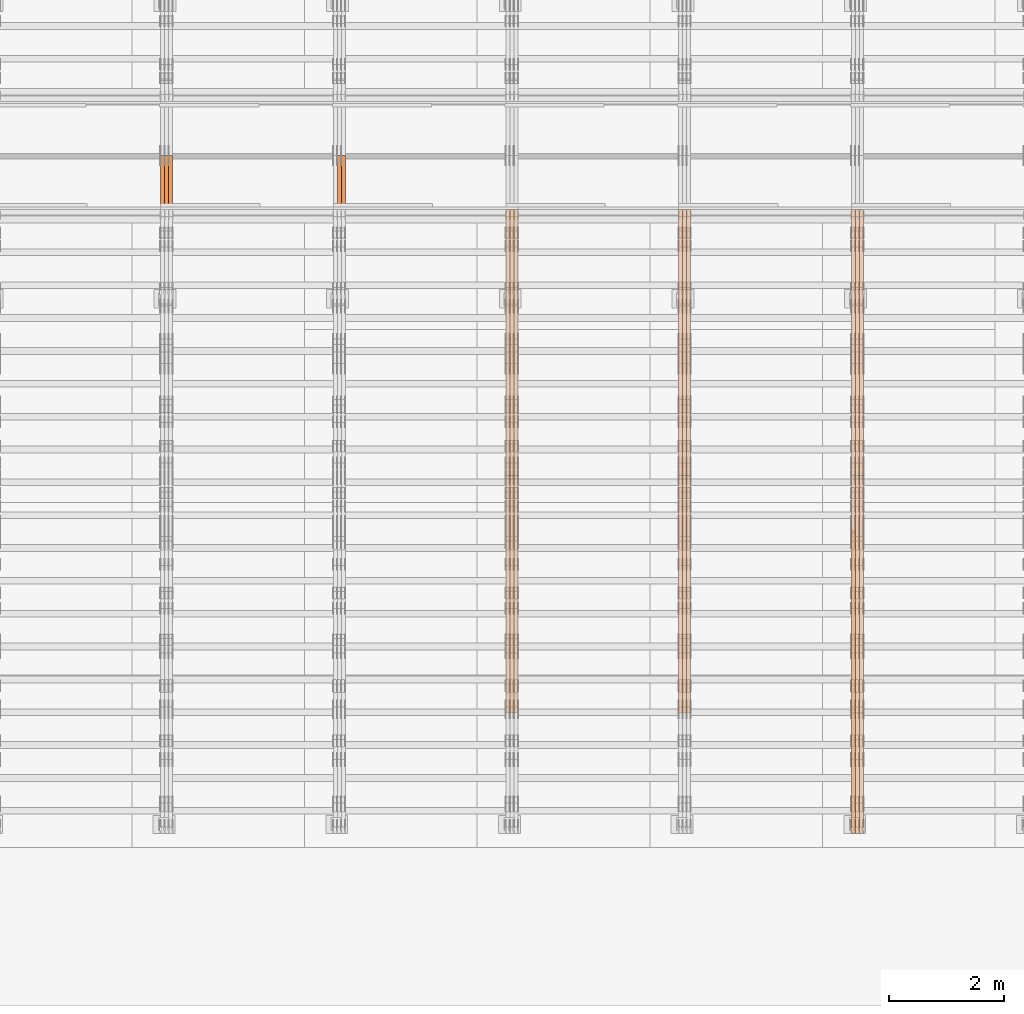
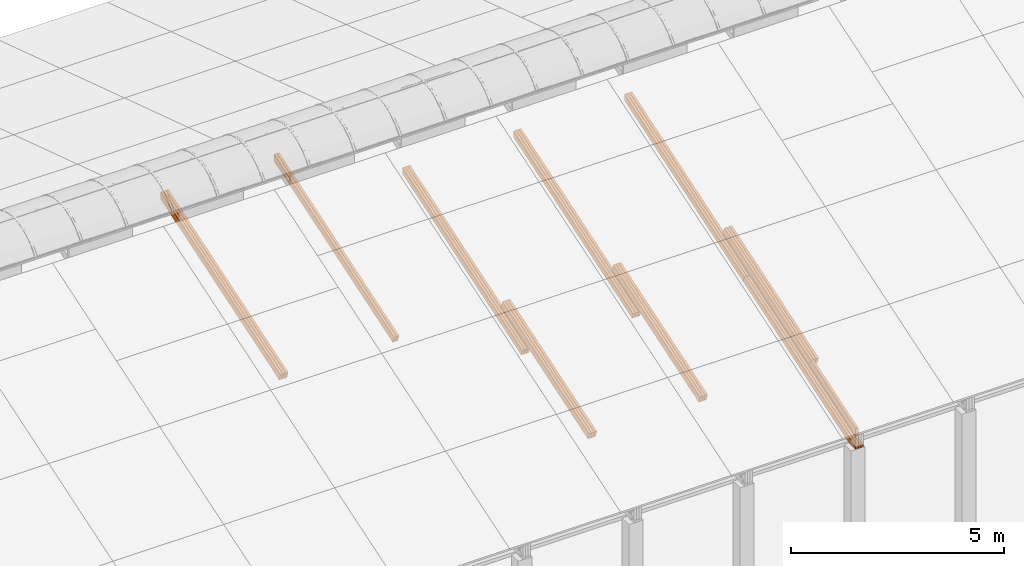
# One storey, part 17 of 385: 27 proxies.
"""IFC2X3 building model written with IfcOpenShell, lengths in millimetres."""

from ifc_helpers import new_model, entity, si_unit, converted_unit, derived_unit, direction, frame, origin, place, context, subcontext, project, spatial, polyline, outline, extrude, source, transform, mapped, material, type_object, type_shapes, element, save


model = new_model("IFC2X3")

# Units and contexts
model_context = context("Model", 3, precision=0.01, world=origin(), true_north=direction((6.12303176911189e-17, 1.0)))
body_context = subcontext(model_context, "Body", "Model", "MODEL_VIEW")
ifc_project = project(units=[si_unit("LENGTHUNIT", "METRE", prefix="MILLI"), si_unit("AREAUNIT", "SQUARE_METRE"), si_unit("VOLUMEUNIT", "CUBIC_METRE"), converted_unit("PLANEANGLEUNIT", "DEGREE", entity("IfcRatioMeasure", 0.0174532925199433), si_unit("PLANEANGLEUNIT", "RADIAN"), dimensions=[0, 0, 0, 0, 0, 0, 0]), si_unit("MASSUNIT", "GRAM", prefix="KILO"), derived_unit("MASSDENSITYUNIT", [(si_unit("MASSUNIT", "GRAM", prefix="KILO"), 1), (si_unit("LENGTHUNIT", "METRE"), -3)]), si_unit("TIMEUNIT", "SECOND"), si_unit("FREQUENCYUNIT", "HERTZ"), si_unit("THERMODYNAMICTEMPERATUREUNIT", "DEGREE_CELSIUS"), derived_unit("THERMALTRANSMITTANCEUNIT", [(si_unit("MASSUNIT", "GRAM", prefix="KILO"), 1), (si_unit("THERMODYNAMICTEMPERATUREUNIT", "KELVIN"), -1), (si_unit("TIMEUNIT", "SECOND"), -3)]), derived_unit("VOLUMETRICFLOWRATEUNIT", [(si_unit("LENGTHUNIT", "METRE"), 3), (si_unit("TIMEUNIT", "SECOND"), -1)]), si_unit("ELECTRICCURRENTUNIT", "AMPERE"), si_unit("ELECTRICVOLTAGEUNIT", "VOLT"), si_unit("POWERUNIT", "WATT"), si_unit("FORCEUNIT", "NEWTON", prefix="KILO"), si_unit("ILLUMINANCEUNIT", "LUX"), si_unit("LUMINOUSFLUXUNIT", "LUMEN"), si_unit("LUMINOUSINTENSITYUNIT", "CANDELA"), derived_unit("USERDEFINED", [(si_unit("MASSUNIT", "GRAM", prefix="KILO"), -1), (si_unit("LENGTHUNIT", "METRE"), -2), (si_unit("TIMEUNIT", "SECOND"), 3), (si_unit("LUMINOUSFLUXUNIT", "LUMEN"), 1)]), derived_unit("LINEARVELOCITYUNIT", [(si_unit("LENGTHUNIT", "METRE"), 1), (si_unit("TIMEUNIT", "SECOND"), -1)]), si_unit("PRESSUREUNIT", "PASCAL"), derived_unit("USERDEFINED", [(si_unit("LENGTHUNIT", "METRE"), -2), (si_unit("MASSUNIT", "GRAM", prefix="KILO"), 1), (si_unit("TIMEUNIT", "SECOND"), -2)])], contexts=[model_context])

# Site, building, storey
site_placement = place(None, origin())
site = spatial("IfcSite", under=ifc_project, at=site_placement, CompositionType="ELEMENT")
building_placement = place(site_placement, origin())
building = spatial("IfcBuilding", under=site, at=building_placement, CompositionType="ELEMENT")
storey_placement = place(building_placement, origin())
storey = spatial("IfcBuildingStorey", under=building, at=storey_placement, Name="Default", CompositionType="ELEMENT", Elevation=0.0)

# Proxies
ifc_material_1 = material(Name="IfcSurfaceStyle #352053")
building_element_proxy_type_1 = type_object("IfcBuildingElementProxyType", Name="T1-T3 352051", PredefinedType="NOTDEFINED", material=ifc_material_1)
shared_shape_1 = source(origin(), body_context, "Body", "SweptSolid", [
    extrude(outline(polyline([(-1085.54462735035, -97.5001496742589), (1117.22361141796, -97.5001496742589), (1117.22498157786, 97.5001496742589), (-1148.90396564547, 97.5001496742589), (-1085.54462735035, -97.5001496742589)])), frame((1117.22498157786, 97.5001496742589, 0.0), z_axis=(0.0, 0.0, 1.0), x_axis=(-1.0, 0.0, 0.0)), (0.0, 0.0, 1.0), 69.9999999999999),
])
type_shapes(building_element_proxy_type_1, [shared_shape_1])
proxy_1_placement = place(building_placement, frame((30245.0, 5095.216796875, 1095.23693847656), z_axis=(-1.0, 0.0, 0.0), x_axis=(0.0, -0.951056516295154, -0.309016994374948)))
element("IfcBuildingElementProxy", 1, at=proxy_1_placement, inside=storey, type_object=building_element_proxy_type_1, material=ifc_material_1, Name="T1-T3", context=body_context, shape_type="MappedRepresentation", body=[
    mapped(shared_shape_1, transform((0.0, 0.0, 0.0), scale=1.0)),
])
ifc_material_2 = material(Name="IfcSurfaceStyle #351996")
building_element_proxy_type_2 = type_object("IfcBuildingElementProxyType", Name="T1-T2 351994", PredefinedType="NOTDEFINED", material=ifc_material_2)
shared_shape_2 = source(origin(), body_context, "Body", "SweptSolid", [
    extrude(outline(polyline([(-2137.04475371072, -97.5001541485635), (2137.04431231695, -97.5001541485635), (2137.0438249446, 97.5001541485636), (-2137.04338355082, 97.5001541485635), (-2137.04475371072, -97.5001541485635)])), frame((2137.04431231695, 97.5003268035489, 0.0), z_axis=(0.0, 0.0, 1.0), x_axis=(-1.0, 0.0, 0.0)), (0.0, 0.0, 1.0), 69.9999999999997),
])
type_shapes(building_element_proxy_type_2, [shared_shape_2])
proxy_2_placement = place(building_placement, frame((30385.0, 9160.11575124697, 2416.00267194857), z_axis=(-1.0, 0.0, 0.0), x_axis=(0.0, -0.951056516295154, -0.309016994374948)))
element("IfcBuildingElementProxy", 2, at=proxy_2_placement, inside=storey, type_object=building_element_proxy_type_2, material=ifc_material_2, Name="T1-T2", context=body_context, shape_type="MappedRepresentation", body=[
    mapped(shared_shape_2, transform((0.0, 0.0, 0.0), scale=1.0)),
])
ifc_material_3 = material(Name="IfcSurfaceStyle #351939")
building_element_proxy_type_3 = type_object("IfcBuildingElementProxyType", Name="T1-T2 351937", PredefinedType="NOTDEFINED", material=ifc_material_3)
shared_shape_3 = source(origin(), body_context, "Body", "SweptSolid", [
    extrude(outline(polyline([(-2137.04475371072, -97.5001541485635), (2137.04431231695, -97.5001541485635), (2137.0438249446, 97.5001541485636), (-2137.04338355082, 97.5001541485635), (-2137.04475371072, -97.5001541485635)])), frame((2137.04431231695, 97.5003268035489, 0.0), z_axis=(0.0, 0.0, 1.0), x_axis=(-1.0, 0.0, 0.0)), (0.0, 0.0, 1.0), 69.9999999999997),
])
type_shapes(building_element_proxy_type_3, [shared_shape_3])
proxy_3_placement = place(building_placement, frame((30315.0, 9160.11575124697, 2416.00267194857), z_axis=(-1.0, 0.0, 0.0), x_axis=(0.0, -0.951056516295154, -0.309016994374948)))
element("IfcBuildingElementProxy", 3, at=proxy_3_placement, inside=storey, type_object=building_element_proxy_type_3, material=ifc_material_3, Name="T1-T2", context=body_context, shape_type="MappedRepresentation", body=[
    mapped(shared_shape_3, transform((0.0, 0.0, 0.0), scale=1.0)),
])
ifc_material_4 = material(Name="IfcSurfaceStyle #351882")
building_element_proxy_type_4 = type_object("IfcBuildingElementProxyType", Name="T1-T2 351880", PredefinedType="NOTDEFINED", material=ifc_material_4)
shared_shape_4 = source(origin(), body_context, "Body", "SweptSolid", [
    extrude(outline(polyline([(-2137.04475371072, -97.5001541485635), (2137.04431231695, -97.5001541485635), (2137.0438249446, 97.5001541485636), (-2137.04338355082, 97.5001541485635), (-2137.04475371072, -97.5001541485635)])), frame((2137.04431231695, 97.5003268035489, 0.0), z_axis=(0.0, 0.0, 1.0), x_axis=(-1.0, 0.0, 0.0)), (0.0, 0.0, 1.0), 69.9999999999997),
])
type_shapes(building_element_proxy_type_4, [shared_shape_4])
proxy_4_placement = place(building_placement, frame((30245.0, 9160.11575124697, 2416.00267194857), z_axis=(-1.0, 0.0, 0.0), x_axis=(0.0, -0.951056516295154, -0.309016994374948)))
element("IfcBuildingElementProxy", 4, at=proxy_4_placement, inside=storey, type_object=building_element_proxy_type_4, material=ifc_material_4, Name="T1-T2", context=body_context, shape_type="MappedRepresentation", body=[
    mapped(shared_shape_4, transform((0.0, 0.0, 0.0), scale=1.0)),
])
ifc_material_5 = material(Name="IfcSurfaceStyle #351654")
building_element_proxy_type_5 = type_object("IfcBuildingElementProxyType", Name="T1-B4 351652", PredefinedType="NOTDEFINED", material=ifc_material_5)
shared_shape_5 = source(origin(), body_context, "Body", "SweptSolid", [
    extrude(outline(polyline([(-2912.13310129284, -85.0000958683222), (2939.75111293783, -85.0000958683222), (2939.75142473078, 85.0000958683222), (-2967.36943637577, 85.0000958683222), (-2912.13310129284, -85.0000958683222)])), frame((2939.75142473078, 85.0000958683222, 0.0), z_axis=(0.0, 0.0, 1.0), x_axis=(-1.0, 0.0, 0.0)), (0.0, 0.0, 1.0), 69.9999999999996),
])
type_shapes(building_element_proxy_type_5, [shared_shape_5])
proxy_5_placement = place(building_placement, frame((30385.0, 8161.994140625, 1765.00476074219), z_axis=(-1.0, 0.0, 0.0), x_axis=(0.0, 0.951056516295124, 0.309016994375039)))
element("IfcBuildingElementProxy", 5, at=proxy_5_placement, inside=storey, type_object=building_element_proxy_type_5, material=ifc_material_5, Name="T1-B4", context=body_context, shape_type="MappedRepresentation", body=[
    mapped(shared_shape_5, transform((0.0, 0.0, 0.0), scale=1.0)),
])
ifc_material_6 = material(Name="IfcSurfaceStyle #351597")
building_element_proxy_type_6 = type_object("IfcBuildingElementProxyType", Name="T1-B4 351595", PredefinedType="NOTDEFINED", material=ifc_material_6)
shared_shape_6 = source(origin(), body_context, "Body", "SweptSolid", [
    extrude(outline(polyline([(-2912.13310129284, -85.0000958683222), (2939.75111293783, -85.0000958683222), (2939.75142473078, 85.0000958683222), (-2967.36943637577, 85.0000958683222), (-2912.13310129284, -85.0000958683222)])), frame((2939.75142473078, 85.0000958683222, 0.0), z_axis=(0.0, 0.0, 1.0), x_axis=(-1.0, 0.0, 0.0)), (0.0, 0.0, 1.0), 69.9999999999996),
])
type_shapes(building_element_proxy_type_6, [shared_shape_6])
proxy_6_placement = place(building_placement, frame((30315.0, 8161.994140625, 1765.00476074219), z_axis=(-1.0, 0.0, 0.0), x_axis=(0.0, 0.951056516295124, 0.309016994375039)))
element("IfcBuildingElementProxy", 6, at=proxy_6_placement, inside=storey, type_object=building_element_proxy_type_6, material=ifc_material_6, Name="T1-B4", context=body_context, shape_type="MappedRepresentation", body=[
    mapped(shared_shape_6, transform((0.0, 0.0, 0.0), scale=1.0)),
])
ifc_material_7 = material(Name="IfcSurfaceStyle #351540")
building_element_proxy_type_7 = type_object("IfcBuildingElementProxyType", Name="T1-B4 351538", PredefinedType="NOTDEFINED", material=ifc_material_7)
shared_shape_7 = source(origin(), body_context, "Body", "SweptSolid", [
    extrude(outline(polyline([(-2912.13310129284, -85.0000958683222), (2939.75111293783, -85.0000958683222), (2939.75142473078, 85.0000958683222), (-2967.36943637577, 85.0000958683222), (-2912.13310129284, -85.0000958683222)])), frame((2939.75142473078, 85.0000958683222, 0.0), z_axis=(0.0, 0.0, 1.0), x_axis=(-1.0, 0.0, 0.0)), (0.0, 0.0, 1.0), 69.9999999999996),
])
type_shapes(building_element_proxy_type_7, [shared_shape_7])
proxy_7_placement = place(building_placement, frame((30245.0, 8161.994140625, 1765.00476074219), z_axis=(-1.0, 0.0, 0.0), x_axis=(0.0, 0.951056516295124, 0.309016994375039)))
element("IfcBuildingElementProxy", 7, at=proxy_7_placement, inside=storey, type_object=building_element_proxy_type_7, material=ifc_material_7, Name="T1-B4", context=body_context, shape_type="MappedRepresentation", body=[
    mapped(shared_shape_7, transform((0.0, 0.0, 0.0), scale=1.0)),
])
ifc_material_8 = material(Name="IfcSurfaceStyle #351483")
building_element_proxy_type_8 = type_object("IfcBuildingElementProxyType", Name="T1-B5 351481", PredefinedType="NOTDEFINED", material=ifc_material_8)
shared_shape_8 = source(origin(), body_context, "Body", "SweptSolid", [
    extrude(outline(polyline([(-3238.20553797979, -89.0131148793731), (1950.26357999126, -89.0131148793731), (2273.6227955316, 16.0525968934038), (2252.52438864378, 80.9868164326712), (-3238.20522618685, 80.9868164326712), (-3238.20553797979, -89.0131148793731)])), frame((2273.6227955316, 80.9869419088758, 0.0), z_axis=(0.0, 0.0, 1.0), x_axis=(-1.0, 0.0, 0.0)), (0.0, 0.0, 1.0), 69.9999999999997),
])
type_shapes(building_element_proxy_type_8, [shared_shape_8])
proxy_8_placement = place(building_placement, frame((30385.0, 2919.93418387161, 61.7562319586341), z_axis=(-1.0, 0.0, 0.0), x_axis=(0.0, 0.951056516295124, 0.309016994375039)))
element("IfcBuildingElementProxy", 8, at=proxy_8_placement, inside=storey, type_object=building_element_proxy_type_8, material=ifc_material_8, Name="T1-B5", context=body_context, shape_type="MappedRepresentation", body=[
    mapped(shared_shape_8, transform((0.0, 0.0, 0.0), scale=1.0)),
])
ifc_material_9 = material(Name="IfcSurfaceStyle #351417")
building_element_proxy_type_9 = type_object("IfcBuildingElementProxyType", Name="T1-B5 351415", PredefinedType="NOTDEFINED", material=ifc_material_9)
shared_shape_9 = source(origin(), body_context, "Body", "SweptSolid", [
    extrude(outline(polyline([(-3238.20553797979, -89.0131148793731), (1950.26357999126, -89.0131148793731), (2273.6227955316, 16.0525968934038), (2252.52438864378, 80.9868164326712), (-3238.20522618685, 80.9868164326712), (-3238.20553797979, -89.0131148793731)])), frame((2273.6227955316, 80.9869419088758, 0.0), z_axis=(0.0, 0.0, 1.0), x_axis=(-1.0, 0.0, 0.0)), (0.0, 0.0, 1.0), 69.9999999999997),
])
type_shapes(building_element_proxy_type_9, [shared_shape_9])
proxy_9_placement = place(building_placement, frame((30315.0, 2919.93418387161, 61.7562319586341), z_axis=(-1.0, 0.0, 0.0), x_axis=(0.0, 0.951056516295124, 0.309016994375039)))
element("IfcBuildingElementProxy", 9, at=proxy_9_placement, inside=storey, type_object=building_element_proxy_type_9, material=ifc_material_9, Name="T1-B5", context=body_context, shape_type="MappedRepresentation", body=[
    mapped(shared_shape_9, transform((0.0, 0.0, 0.0), scale=1.0)),
])
ifc_material_10 = material(Name="IfcSurfaceStyle #351351")
building_element_proxy_type_10 = type_object("IfcBuildingElementProxyType", Name="T1-B5 351349", PredefinedType="NOTDEFINED", material=ifc_material_10)
shared_shape_10 = source(origin(), body_context, "Body", "SweptSolid", [
    extrude(outline(polyline([(-3238.20553797979, -89.0131148793731), (1950.26357999126, -89.0131148793731), (2273.6227955316, 16.0525968934038), (2252.52438864378, 80.9868164326712), (-3238.20522618685, 80.9868164326712), (-3238.20553797979, -89.0131148793731)])), frame((2273.6227955316, 80.9869419088758, 0.0), z_axis=(0.0, 0.0, 1.0), x_axis=(-1.0, 0.0, 0.0)), (0.0, 0.0, 1.0), 69.9999999999997),
])
type_shapes(building_element_proxy_type_10, [shared_shape_10])
proxy_10_placement = place(building_placement, frame((30245.0, 2919.93418387161, 61.7562319586341), z_axis=(-1.0, 0.0, 0.0), x_axis=(0.0, 0.951056516295124, 0.309016994375039)))
element("IfcBuildingElementProxy", 10, at=proxy_10_placement, inside=storey, type_object=building_element_proxy_type_10, material=ifc_material_10, Name="T1-B5", context=body_context, shape_type="MappedRepresentation", body=[
    mapped(shared_shape_10, transform((0.0, 0.0, 0.0), scale=1.0)),
])
ifc_material_11 = material(Name="IfcSurfaceStyle #317564")
building_element_proxy_type_11 = type_object("IfcBuildingElementProxyType", Name="T1-T2 317562", PredefinedType="NOTDEFINED", material=ifc_material_11)
shared_shape_11 = source(origin(), body_context, "Body", "SweptSolid", [
    extrude(outline(polyline([(-2137.04475371072, -97.5001541485635), (2137.04431231695, -97.5001541485635), (2137.0438249446, 97.5001541485636), (-2137.04338355082, 97.5001541485635), (-2137.04475371072, -97.5001541485635)])), frame((2137.04431231695, 97.5003268035489, 0.0), z_axis=(0.0, 0.0, 1.0), x_axis=(-1.0, 0.0, 0.0)), (0.0, 0.0, 1.0), 69.9999999999997),
])
type_shapes(building_element_proxy_type_11, [shared_shape_11])
proxy_11_placement = place(building_placement, frame((27385.0, 9160.11575124698, 2416.00267194857), z_axis=(-1.0, 0.0, 0.0), x_axis=(0.0, -0.951056516295154, -0.309016994374948)))
element("IfcBuildingElementProxy", 11, at=proxy_11_placement, inside=storey, type_object=building_element_proxy_type_11, material=ifc_material_11, Name="T1-T2", context=body_context, shape_type="MappedRepresentation", body=[
    mapped(shared_shape_11, transform((0.0, 0.0, 0.0), scale=1.0)),
])
ifc_material_12 = material(Name="IfcSurfaceStyle #317507")
building_element_proxy_type_12 = type_object("IfcBuildingElementProxyType", Name="T1-T2 317505", PredefinedType="NOTDEFINED", material=ifc_material_12)
shared_shape_12 = source(origin(), body_context, "Body", "SweptSolid", [
    extrude(outline(polyline([(-2137.04475371072, -97.5001541485635), (2137.04431231695, -97.5001541485635), (2137.0438249446, 97.5001541485636), (-2137.04338355082, 97.5001541485635), (-2137.04475371072, -97.5001541485635)])), frame((2137.04431231695, 97.5003268035489, 0.0), z_axis=(0.0, 0.0, 1.0), x_axis=(-1.0, 0.0, 0.0)), (0.0, 0.0, 1.0), 69.9999999999997),
])
type_shapes(building_element_proxy_type_12, [shared_shape_12])
proxy_12_placement = place(building_placement, frame((27315.0, 9160.11575124698, 2416.00267194857), z_axis=(-1.0, 0.0, 0.0), x_axis=(0.0, -0.951056516295154, -0.309016994374948)))
element("IfcBuildingElementProxy", 12, at=proxy_12_placement, inside=storey, type_object=building_element_proxy_type_12, material=ifc_material_12, Name="T1-T2", context=body_context, shape_type="MappedRepresentation", body=[
    mapped(shared_shape_12, transform((0.0, 0.0, 0.0), scale=1.0)),
])
ifc_material_13 = material(Name="IfcSurfaceStyle #317450")
building_element_proxy_type_13 = type_object("IfcBuildingElementProxyType", Name="T1-T2 317448", PredefinedType="NOTDEFINED", material=ifc_material_13)
shared_shape_13 = source(origin(), body_context, "Body", "SweptSolid", [
    extrude(outline(polyline([(-2137.04475371072, -97.5001541485635), (2137.04431231695, -97.5001541485635), (2137.0438249446, 97.5001541485636), (-2137.04338355082, 97.5001541485635), (-2137.04475371072, -97.5001541485635)])), frame((2137.04431231695, 97.5003268035489, 0.0), z_axis=(0.0, 0.0, 1.0), x_axis=(-1.0, 0.0, 0.0)), (0.0, 0.0, 1.0), 69.9999999999997),
])
type_shapes(building_element_proxy_type_13, [shared_shape_13])
proxy_13_placement = place(building_placement, frame((27245.0, 9160.11575124698, 2416.00267194857), z_axis=(-1.0, 0.0, 0.0), x_axis=(0.0, -0.951056516295154, -0.309016994374948)))
element("IfcBuildingElementProxy", 13, at=proxy_13_placement, inside=storey, type_object=building_element_proxy_type_13, material=ifc_material_13, Name="T1-T2", context=body_context, shape_type="MappedRepresentation", body=[
    mapped(shared_shape_13, transform((0.0, 0.0, 0.0), scale=1.0)),
])
ifc_material_14 = material(Name="IfcSurfaceStyle #317222")
building_element_proxy_type_14 = type_object("IfcBuildingElementProxyType", Name="T1-B4 317220", PredefinedType="NOTDEFINED", material=ifc_material_14)
shared_shape_14 = source(origin(), body_context, "Body", "SweptSolid", [
    extrude(outline(polyline([(-2912.13310129284, -85.0000958683222), (2939.75111293783, -85.0000958683222), (2939.75142473078, 85.0000958683222), (-2967.36943637577, 85.0000958683222), (-2912.13310129284, -85.0000958683222)])), frame((2939.75142473078, 85.0000958683222, 0.0), z_axis=(0.0, 0.0, 1.0), x_axis=(-1.0, 0.0, 0.0)), (0.0, 0.0, 1.0), 69.9999999999996),
])
type_shapes(building_element_proxy_type_14, [shared_shape_14])
proxy_14_placement = place(building_placement, frame((27385.0, 8161.994140625, 1765.00476074219), z_axis=(-1.0, 0.0, 0.0), x_axis=(0.0, 0.951056516295124, 0.309016994375039)))
element("IfcBuildingElementProxy", 14, at=proxy_14_placement, inside=storey, type_object=building_element_proxy_type_14, material=ifc_material_14, Name="T1-B4", context=body_context, shape_type="MappedRepresentation", body=[
    mapped(shared_shape_14, transform((0.0, 0.0, 0.0), scale=1.0)),
])
ifc_material_15 = material(Name="IfcSurfaceStyle #317165")
building_element_proxy_type_15 = type_object("IfcBuildingElementProxyType", Name="T1-B4 317163", PredefinedType="NOTDEFINED", material=ifc_material_15)
shared_shape_15 = source(origin(), body_context, "Body", "SweptSolid", [
    extrude(outline(polyline([(-2912.13310129284, -85.0000958683222), (2939.75111293783, -85.0000958683222), (2939.75142473078, 85.0000958683222), (-2967.36943637577, 85.0000958683222), (-2912.13310129284, -85.0000958683222)])), frame((2939.75142473078, 85.0000958683222, 0.0), z_axis=(0.0, 0.0, 1.0), x_axis=(-1.0, 0.0, 0.0)), (0.0, 0.0, 1.0), 69.9999999999996),
])
type_shapes(building_element_proxy_type_15, [shared_shape_15])
proxy_15_placement = place(building_placement, frame((27315.0, 8161.994140625, 1765.00476074219), z_axis=(-1.0, 0.0, 0.0), x_axis=(0.0, 0.951056516295124, 0.309016994375039)))
element("IfcBuildingElementProxy", 15, at=proxy_15_placement, inside=storey, type_object=building_element_proxy_type_15, material=ifc_material_15, Name="T1-B4", context=body_context, shape_type="MappedRepresentation", body=[
    mapped(shared_shape_15, transform((0.0, 0.0, 0.0), scale=1.0)),
])
ifc_material_16 = material(Name="IfcSurfaceStyle #317108")
building_element_proxy_type_16 = type_object("IfcBuildingElementProxyType", Name="T1-B4 317106", PredefinedType="NOTDEFINED", material=ifc_material_16)
shared_shape_16 = source(origin(), body_context, "Body", "SweptSolid", [
    extrude(outline(polyline([(-2912.13310129284, -85.0000958683222), (2939.75111293783, -85.0000958683222), (2939.75142473078, 85.0000958683222), (-2967.36943637577, 85.0000958683222), (-2912.13310129284, -85.0000958683222)])), frame((2939.75142473078, 85.0000958683222, 0.0), z_axis=(0.0, 0.0, 1.0), x_axis=(-1.0, 0.0, 0.0)), (0.0, 0.0, 1.0), 69.9999999999996),
])
type_shapes(building_element_proxy_type_16, [shared_shape_16])
proxy_16_placement = place(building_placement, frame((27245.0, 8161.994140625, 1765.00476074219), z_axis=(-1.0, 0.0, 0.0), x_axis=(0.0, 0.951056516295124, 0.309016994375039)))
element("IfcBuildingElementProxy", 16, at=proxy_16_placement, inside=storey, type_object=building_element_proxy_type_16, material=ifc_material_16, Name="T1-B4", context=body_context, shape_type="MappedRepresentation", body=[
    mapped(shared_shape_16, transform((0.0, 0.0, 0.0), scale=1.0)),
])
ifc_material_17 = material(Name="IfcSurfaceStyle #283132")
building_element_proxy_type_17 = type_object("IfcBuildingElementProxyType", Name="T1-T2 283130", PredefinedType="NOTDEFINED", material=ifc_material_17)
shared_shape_17 = source(origin(), body_context, "Body", "SweptSolid", [
    extrude(outline(polyline([(-2137.04475371072, -97.5001541485635), (2137.04431231695, -97.5001541485635), (2137.0438249446, 97.5001541485636), (-2137.04338355082, 97.5001541485635), (-2137.04475371072, -97.5001541485635)])), frame((2137.04431231695, 97.5003268035489, 0.0), z_axis=(0.0, 0.0, 1.0), x_axis=(-1.0, 0.0, 0.0)), (0.0, 0.0, 1.0), 69.9999999999997),
])
type_shapes(building_element_proxy_type_17, [shared_shape_17])
proxy_17_placement = place(building_placement, frame((24385.0, 9160.11575124697, 2416.00267194857), z_axis=(-1.0, 0.0, 0.0), x_axis=(0.0, -0.951056516295154, -0.309016994374948)))
element("IfcBuildingElementProxy", 17, at=proxy_17_placement, inside=storey, type_object=building_element_proxy_type_17, material=ifc_material_17, Name="T1-T2", context=body_context, shape_type="MappedRepresentation", body=[
    mapped(shared_shape_17, transform((0.0, 0.0, 0.0), scale=1.0)),
])
ifc_material_18 = material(Name="IfcSurfaceStyle #283075")
building_element_proxy_type_18 = type_object("IfcBuildingElementProxyType", Name="T1-T2 283073", PredefinedType="NOTDEFINED", material=ifc_material_18)
shared_shape_18 = source(origin(), body_context, "Body", "SweptSolid", [
    extrude(outline(polyline([(-2137.04475371072, -97.5001541485635), (2137.04431231695, -97.5001541485635), (2137.0438249446, 97.5001541485636), (-2137.04338355082, 97.5001541485635), (-2137.04475371072, -97.5001541485635)])), frame((2137.04431231695, 97.5003268035489, 0.0), z_axis=(0.0, 0.0, 1.0), x_axis=(-1.0, 0.0, 0.0)), (0.0, 0.0, 1.0), 69.9999999999997),
])
type_shapes(building_element_proxy_type_18, [shared_shape_18])
proxy_18_placement = place(building_placement, frame((24315.0, 9160.11575124697, 2416.00267194857), z_axis=(-1.0, 0.0, 0.0), x_axis=(0.0, -0.951056516295154, -0.309016994374948)))
element("IfcBuildingElementProxy", 18, at=proxy_18_placement, inside=storey, type_object=building_element_proxy_type_18, material=ifc_material_18, Name="T1-T2", context=body_context, shape_type="MappedRepresentation", body=[
    mapped(shared_shape_18, transform((0.0, 0.0, 0.0), scale=1.0)),
])
ifc_material_19 = material(Name="IfcSurfaceStyle #283018")
building_element_proxy_type_19 = type_object("IfcBuildingElementProxyType", Name="T1-T2 283016", PredefinedType="NOTDEFINED", material=ifc_material_19)
shared_shape_19 = source(origin(), body_context, "Body", "SweptSolid", [
    extrude(outline(polyline([(-2137.04475371072, -97.5001541485635), (2137.04431231695, -97.5001541485635), (2137.0438249446, 97.5001541485636), (-2137.04338355082, 97.5001541485635), (-2137.04475371072, -97.5001541485635)])), frame((2137.04431231695, 97.5003268035489, 0.0), z_axis=(0.0, 0.0, 1.0), x_axis=(-1.0, 0.0, 0.0)), (0.0, 0.0, 1.0), 69.9999999999997),
])
type_shapes(building_element_proxy_type_19, [shared_shape_19])
proxy_19_placement = place(building_placement, frame((24245.0, 9160.11575124697, 2416.00267194857), z_axis=(-1.0, 0.0, 0.0), x_axis=(0.0, -0.951056516295154, -0.309016994374948)))
element("IfcBuildingElementProxy", 19, at=proxy_19_placement, inside=storey, type_object=building_element_proxy_type_19, material=ifc_material_19, Name="T1-T2", context=body_context, shape_type="MappedRepresentation", body=[
    mapped(shared_shape_19, transform((0.0, 0.0, 0.0), scale=1.0)),
])
ifc_material_20 = material(Name="IfcSurfaceStyle #282790")
building_element_proxy_type_20 = type_object("IfcBuildingElementProxyType", Name="T1-B4 282788", PredefinedType="NOTDEFINED", material=ifc_material_20)
shared_shape_20 = source(origin(), body_context, "Body", "SweptSolid", [
    extrude(outline(polyline([(-2912.13310129284, -85.0000958683222), (2939.75111293783, -85.0000958683222), (2939.75142473078, 85.0000958683222), (-2967.36943637577, 85.0000958683222), (-2912.13310129284, -85.0000958683222)])), frame((2939.75142473078, 85.0000958683222, 0.0), z_axis=(0.0, 0.0, 1.0), x_axis=(-1.0, 0.0, 0.0)), (0.0, 0.0, 1.0), 69.9999999999996),
])
type_shapes(building_element_proxy_type_20, [shared_shape_20])
proxy_20_placement = place(building_placement, frame((24385.0, 8161.994140625, 1765.00476074219), z_axis=(-1.0, 0.0, 0.0), x_axis=(0.0, 0.951056516295124, 0.309016994375039)))
element("IfcBuildingElementProxy", 20, at=proxy_20_placement, inside=storey, type_object=building_element_proxy_type_20, material=ifc_material_20, Name="T1-B4", context=body_context, shape_type="MappedRepresentation", body=[
    mapped(shared_shape_20, transform((0.0, 0.0, 0.0), scale=1.0)),
])
ifc_material_21 = material(Name="IfcSurfaceStyle #282733")
building_element_proxy_type_21 = type_object("IfcBuildingElementProxyType", Name="T1-B4 282731", PredefinedType="NOTDEFINED", material=ifc_material_21)
shared_shape_21 = source(origin(), body_context, "Body", "SweptSolid", [
    extrude(outline(polyline([(-2912.13310129284, -85.0000958683222), (2939.75111293783, -85.0000958683222), (2939.75142473078, 85.0000958683222), (-2967.36943637577, 85.0000958683222), (-2912.13310129284, -85.0000958683222)])), frame((2939.75142473078, 85.0000958683222, 0.0), z_axis=(0.0, 0.0, 1.0), x_axis=(-1.0, 0.0, 0.0)), (0.0, 0.0, 1.0), 69.9999999999996),
])
type_shapes(building_element_proxy_type_21, [shared_shape_21])
proxy_21_placement = place(building_placement, frame((24315.0, 8161.994140625, 1765.00476074219), z_axis=(-1.0, 0.0, 0.0), x_axis=(0.0, 0.951056516295124, 0.309016994375039)))
element("IfcBuildingElementProxy", 21, at=proxy_21_placement, inside=storey, type_object=building_element_proxy_type_21, material=ifc_material_21, Name="T1-B4", context=body_context, shape_type="MappedRepresentation", body=[
    mapped(shared_shape_21, transform((0.0, 0.0, 0.0), scale=1.0)),
])
ifc_material_22 = material(Name="IfcSurfaceStyle #282676")
building_element_proxy_type_22 = type_object("IfcBuildingElementProxyType", Name="T1-B4 282674", PredefinedType="NOTDEFINED", material=ifc_material_22)
shared_shape_22 = source(origin(), body_context, "Body", "SweptSolid", [
    extrude(outline(polyline([(-2912.13310129284, -85.0000958683222), (2939.75111293783, -85.0000958683222), (2939.75142473078, 85.0000958683222), (-2967.36943637577, 85.0000958683222), (-2912.13310129284, -85.0000958683222)])), frame((2939.75142473078, 85.0000958683222, 0.0), z_axis=(0.0, 0.0, 1.0), x_axis=(-1.0, 0.0, 0.0)), (0.0, 0.0, 1.0), 69.9999999999996),
])
type_shapes(building_element_proxy_type_22, [shared_shape_22])
proxy_22_placement = place(building_placement, frame((24245.0, 8161.994140625, 1765.00476074219), z_axis=(-1.0, 0.0, 0.0), x_axis=(0.0, 0.951056516295124, 0.309016994375039)))
element("IfcBuildingElementProxy", 22, at=proxy_22_placement, inside=storey, type_object=building_element_proxy_type_22, material=ifc_material_22, Name="T1-B4", context=body_context, shape_type="MappedRepresentation", body=[
    mapped(shared_shape_22, transform((0.0, 0.0, 0.0), scale=1.0)),
])
ifc_material_23 = material(Name="IfcSurfaceStyle #248529")
building_element_proxy_type_23 = type_object("IfcBuildingElementProxyType", Name="T1-T1 248527", PredefinedType="NOTDEFINED", material=ifc_material_23)
shared_shape_23 = source(origin(), body_context, "Body", "SweptSolid", [
    extrude(outline(polyline([(-2938.84391703088, -97.499801613968), (2970.52383457984, -97.499801613968), (2907.16448685427, 97.499801613968), (-2938.84440440323, 97.499801613968), (-2938.84391703088, -97.499801613968)])), frame((2970.52383457984, 97.5000757893295, 0.0), z_axis=(0.0, 0.0, 1.0), x_axis=(-1.0, 0.0, 0.0)), (0.0, 0.0, 1.0), 69.9999999999996),
])
type_shapes(building_element_proxy_type_23, [shared_shape_23])
proxy_23_placement = place(building_placement, frame((21385.0, 14780.2584052475, 4242.0978974122), z_axis=(-1.0, 0.0, 0.0), x_axis=(0.0, -0.951056516295154, -0.309016994374948)))
element("IfcBuildingElementProxy", 23, at=proxy_23_placement, inside=storey, type_object=building_element_proxy_type_23, material=ifc_material_23, Name="T1-T1", context=body_context, shape_type="MappedRepresentation", body=[
    mapped(shared_shape_23, transform((0.0, 0.0, 0.0), scale=1.0)),
])
ifc_material_24 = material(Name="IfcSurfaceStyle #248472")
building_element_proxy_type_24 = type_object("IfcBuildingElementProxyType", Name="T1-T1 248470", PredefinedType="NOTDEFINED", material=ifc_material_24)
shared_shape_24 = source(origin(), body_context, "Body", "SweptSolid", [
    extrude(outline(polyline([(-2938.84391703088, -97.499801613968), (2970.52383457984, -97.499801613968), (2907.16448685427, 97.499801613968), (-2938.84440440323, 97.499801613968), (-2938.84391703088, -97.499801613968)])), frame((2970.52383457984, 97.5000757893295, 0.0), z_axis=(0.0, 0.0, 1.0), x_axis=(-1.0, 0.0, 0.0)), (0.0, 0.0, 1.0), 69.9999999999996),
])
type_shapes(building_element_proxy_type_24, [shared_shape_24])
proxy_24_placement = place(building_placement, frame((21315.0, 14780.2584052475, 4242.0978974122), z_axis=(-1.0, 0.0, 0.0), x_axis=(0.0, -0.951056516295154, -0.309016994374948)))
element("IfcBuildingElementProxy", 24, at=proxy_24_placement, inside=storey, type_object=building_element_proxy_type_24, material=ifc_material_24, Name="T1-T1", context=body_context, shape_type="MappedRepresentation", body=[
    mapped(shared_shape_24, transform((0.0, 0.0, 0.0), scale=1.0)),
])
ifc_material_25 = material(Name="IfcSurfaceStyle #214097")
building_element_proxy_type_25 = type_object("IfcBuildingElementProxyType", Name="T1-T1 214095", PredefinedType="NOTDEFINED", material=ifc_material_25)
shared_shape_25 = source(origin(), body_context, "Body", "SweptSolid", [
    extrude(outline(polyline([(-2938.84391703088, -97.499801613968), (2970.52383457984, -97.499801613968), (2907.16448685427, 97.499801613968), (-2938.84440440323, 97.499801613968), (-2938.84391703088, -97.499801613968)])), frame((2970.52383457984, 97.5000757893295, 0.0), z_axis=(0.0, 0.0, 1.0), x_axis=(-1.0, 0.0, 0.0)), (0.0, 0.0, 1.0), 69.9999999999996),
])
type_shapes(building_element_proxy_type_25, [shared_shape_25])
proxy_25_placement = place(building_placement, frame((18385.0, 14780.2584052475, 4242.0978974122), z_axis=(-1.0, 0.0, 0.0), x_axis=(0.0, -0.951056516295154, -0.309016994374948)))
element("IfcBuildingElementProxy", 25, at=proxy_25_placement, inside=storey, type_object=building_element_proxy_type_25, material=ifc_material_25, Name="T1-T1", context=body_context, shape_type="MappedRepresentation", body=[
    mapped(shared_shape_25, transform((0.0, 0.0, 0.0), scale=1.0)),
])
ifc_material_26 = material(Name="IfcSurfaceStyle #214040")
building_element_proxy_type_26 = type_object("IfcBuildingElementProxyType", Name="T1-T1 214038", PredefinedType="NOTDEFINED", material=ifc_material_26)
shared_shape_26 = source(origin(), body_context, "Body", "SweptSolid", [
    extrude(outline(polyline([(-2938.84391703088, -97.499801613968), (2970.52383457984, -97.499801613968), (2907.16448685427, 97.499801613968), (-2938.84440440323, 97.499801613968), (-2938.84391703088, -97.499801613968)])), frame((2970.52383457984, 97.5000757893295, 0.0), z_axis=(0.0, 0.0, 1.0), x_axis=(-1.0, 0.0, 0.0)), (0.0, 0.0, 1.0), 69.9999999999996),
])
type_shapes(building_element_proxy_type_26, [shared_shape_26])
proxy_26_placement = place(building_placement, frame((18315.0, 14780.2584052475, 4242.0978974122), z_axis=(-1.0, 0.0, 0.0), x_axis=(0.0, -0.951056516295154, -0.309016994374948)))
element("IfcBuildingElementProxy", 26, at=proxy_26_placement, inside=storey, type_object=building_element_proxy_type_26, material=ifc_material_26, Name="T1-T1", context=body_context, shape_type="MappedRepresentation", body=[
    mapped(shared_shape_26, transform((0.0, 0.0, 0.0), scale=1.0)),
])
ifc_material_27 = material(Name="IfcSurfaceStyle #213983")
building_element_proxy_type_27 = type_object("IfcBuildingElementProxyType", Name="T1-T1 213981", PredefinedType="NOTDEFINED", material=ifc_material_27)
shared_shape_27 = source(origin(), body_context, "Body", "SweptSolid", [
    extrude(outline(polyline([(-2938.84391703088, -97.499801613968), (2970.52383457984, -97.499801613968), (2907.16448685427, 97.499801613968), (-2938.84440440323, 97.499801613968), (-2938.84391703088, -97.499801613968)])), frame((2970.52383457984, 97.5000757893295, 0.0), z_axis=(0.0, 0.0, 1.0), x_axis=(-1.0, 0.0, 0.0)), (0.0, 0.0, 1.0), 69.9999999999996),
])
type_shapes(building_element_proxy_type_27, [shared_shape_27])
proxy_27_placement = place(building_placement, frame((18245.0, 14780.2584052475, 4242.0978974122), z_axis=(-1.0, 0.0, 0.0), x_axis=(0.0, -0.951056516295154, -0.309016994374948)))
element("IfcBuildingElementProxy", 27, at=proxy_27_placement, inside=storey, type_object=building_element_proxy_type_27, material=ifc_material_27, Name="T1-T1", context=body_context, shape_type="MappedRepresentation", body=[
    mapped(shared_shape_27, transform((0.0, 0.0, 0.0), scale=1.0)),
])

save(model, "model.ifc")
